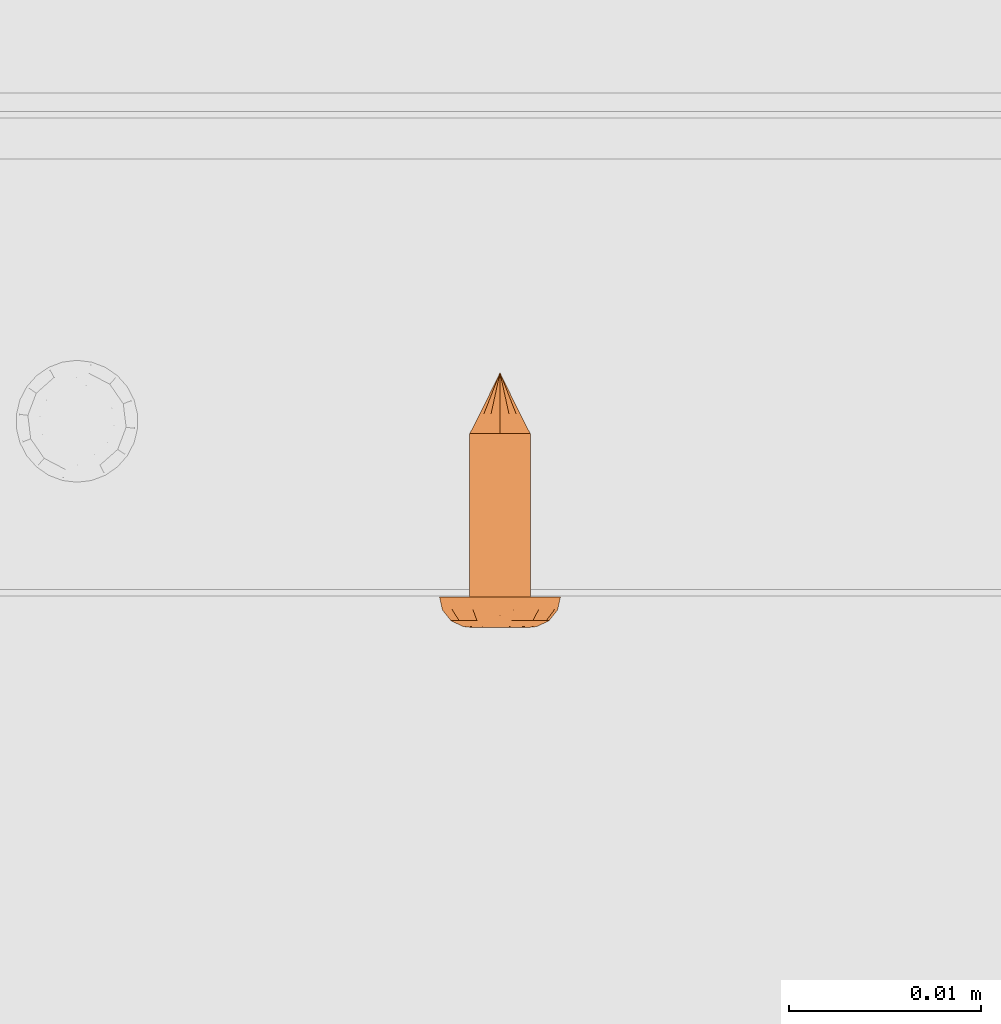
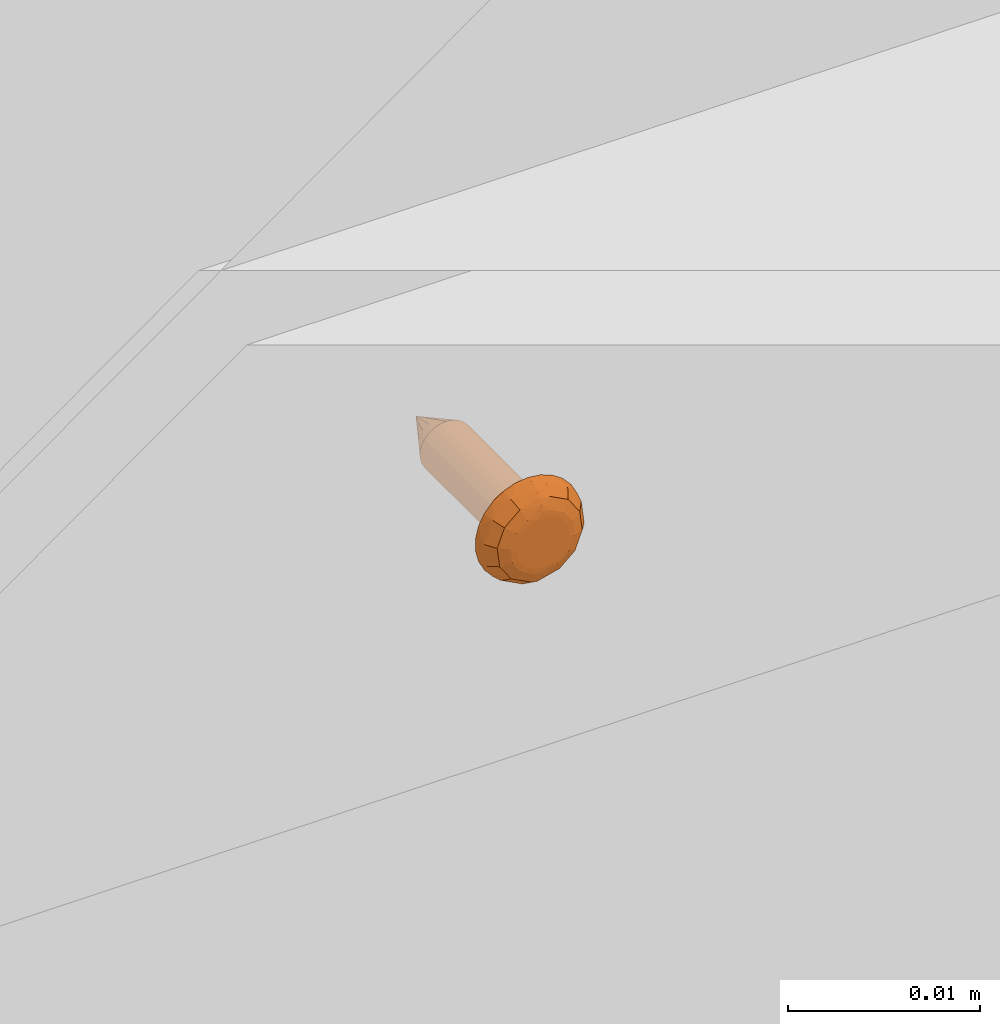
# One storey, part 44 of 44: 1 proxy.
"""IFC4 building model written with IfcOpenShell, lengths in feet."""

from ifc_helpers import new_model, entity, si_unit, converted_unit, derived_unit, direction, frame, origin, place, context, subcontext, project, spatial, source, transform, mapped, material, type_object, type_shapes, element, save


model = new_model("IFC4")

# Units and contexts
model_context = context("Model", 3, precision=0.0001, world=origin(), true_north=direction((6.12303176911189e-17, 1.0)))
body_context = subcontext(model_context, "Body", "Model", "MODEL_VIEW")
ifc_project = project(units=[converted_unit("LENGTHUNIT", "FOOT", entity("IfcRatioMeasure", 0.3048), si_unit("LENGTHUNIT", "METRE"), dimensions=[1, 0, 0, 0, 0, 0, 0]), converted_unit("AREAUNIT", "SQUARE FOOT", entity("IfcRatioMeasure", 0.09290304), si_unit("AREAUNIT", "SQUARE_METRE"), dimensions=[2, 0, 0, 0, 0, 0, 0]), converted_unit("VOLUMEUNIT", "CUBIC FOOT", entity("IfcRatioMeasure", 0.028316846592), si_unit("VOLUMEUNIT", "CUBIC_METRE"), dimensions=[3, 0, 0, 0, 0, 0, 0]), converted_unit("PLANEANGLEUNIT", "DEGREE", entity("IfcRatioMeasure", 0.0174532925199433), si_unit("PLANEANGLEUNIT", "RADIAN"), dimensions=[0, 0, 0, 0, 0, 0, 0]), si_unit("MASSUNIT", "GRAM", prefix="KILO"), derived_unit("MASSDENSITYUNIT", [(si_unit("MASSUNIT", "GRAM", prefix="KILO"), 1), (si_unit("LENGTHUNIT", "METRE"), -3)]), derived_unit("MOMENTOFINERTIAUNIT", [(si_unit("LENGTHUNIT", "METRE"), 4)]), si_unit("TIMEUNIT", "SECOND"), si_unit("FREQUENCYUNIT", "HERTZ"), si_unit("THERMODYNAMICTEMPERATUREUNIT", "DEGREE_CELSIUS"), derived_unit("THERMALTRANSMITTANCEUNIT", [(si_unit("MASSUNIT", "GRAM", prefix="KILO"), 1), (si_unit("THERMODYNAMICTEMPERATUREUNIT", "KELVIN"), -1), (si_unit("TIMEUNIT", "SECOND"), -3)]), derived_unit("VOLUMETRICFLOWRATEUNIT", [(si_unit("LENGTHUNIT", "METRE"), 3), (si_unit("TIMEUNIT", "SECOND"), -1)]), si_unit("ELECTRICCURRENTUNIT", "AMPERE"), si_unit("ELECTRICVOLTAGEUNIT", "VOLT"), si_unit("POWERUNIT", "WATT"), si_unit("FORCEUNIT", "NEWTON"), si_unit("ILLUMINANCEUNIT", "LUX"), si_unit("LUMINOUSFLUXUNIT", "LUMEN"), si_unit("LUMINOUSINTENSITYUNIT", "CANDELA"), derived_unit("USERDEFINED", [(si_unit("MASSUNIT", "GRAM", prefix="KILO"), -1), (si_unit("LENGTHUNIT", "METRE"), -2), (si_unit("TIMEUNIT", "SECOND"), 3), (si_unit("LUMINOUSFLUXUNIT", "LUMEN"), 1)]), derived_unit("LINEARVELOCITYUNIT", [(si_unit("LENGTHUNIT", "METRE"), 1), (si_unit("TIMEUNIT", "SECOND"), -1)]), si_unit("PRESSUREUNIT", "PASCAL"), derived_unit("USERDEFINED", [(si_unit("LENGTHUNIT", "METRE"), -2), (si_unit("MASSUNIT", "GRAM", prefix="KILO"), 1), (si_unit("TIMEUNIT", "SECOND"), -2)]), derived_unit("LINEARFORCEUNIT", [(si_unit("MASSUNIT", "GRAM", prefix="KILO"), 1), (si_unit("LENGTHUNIT", "METRE"), 1), (si_unit("TIMEUNIT", "SECOND"), -2), (si_unit("LENGTHUNIT", "METRE"), -1)]), derived_unit("PLANARFORCEUNIT", [(si_unit("MASSUNIT", "GRAM", prefix="KILO"), 1), (si_unit("LENGTHUNIT", "METRE"), 1), (si_unit("TIMEUNIT", "SECOND"), -2), (si_unit("LENGTHUNIT", "METRE"), -2)])], contexts=[model_context])

# Site, building, storey
site_placement = place(None, origin())
site = spatial("IfcSite", under=ifc_project, at=site_placement, CompositionType="ELEMENT")
building_placement = place(site_placement, origin())
building = spatial("IfcBuilding", under=site, at=building_placement, CompositionType="ELEMENT")
storey_placement = place(building_placement, origin())
storey = spatial("IfcBuildingStorey", under=building, at=storey_placement, CompositionType="ELEMENT", Elevation=0.0)

# Proxy
ifc_material = material(Category="Materials")
building_element_proxy_type = type_object("IfcBuildingElementProxyType", PredefinedType="NOTDEFINED", material=ifc_material)
cartesian_point_1 = entity("IfcCartesianPoint", [0.0, -0.00520833333344342, -0.0278812538651513])
vertex_point_1 = entity("IfcVertexPoint", cartesian_point_1)
cartesian_point_2 = entity("IfcCartesianPoint", [0.0, 0.00520833333334731, -0.0278812538651514])
vertex_point_2 = entity("IfcVertexPoint", cartesian_point_2)
cartesian_point_3 = entity("IfcCartesianPoint", [0.0, 0.0, -0.0278812538651514])
ifc_direction_1 = entity("IfcDirection", [0.0, 0.0, 1.0])
ifc_direction_2 = entity("IfcDirection", [0.0, 1.0, 0.0])
edge_curve_1 = entity("IfcEdgeCurve", vertex_point_1, vertex_point_2, entity("IfcTrimmedCurve", entity("IfcCircle", entity("IfcAxis2Placement3D", cartesian_point_3, ifc_direction_1, ifc_direction_2), 0.00520833333339537), [cartesian_point_1], [cartesian_point_2], True, "CARTESIAN"), True)
vertex_point_3 = entity("IfcVertexPoint", cartesian_point_3)
ifc_direction_3 = entity("IfcDirection", [0.0, -1.0, 0.0])
edge_curve_2 = entity("IfcEdgeCurve", vertex_point_2, vertex_point_3, entity("IfcTrimmedCurve", entity("IfcLine", cartesian_point_2, entity("IfcVector", ifc_direction_3, 1.0)), [cartesian_point_2], [cartesian_point_3], True, "CARTESIAN"), True)
edge_curve_3 = entity("IfcEdgeCurve", vertex_point_3, vertex_point_1, entity("IfcTrimmedCurve", entity("IfcLine", cartesian_point_3, entity("IfcVector", ifc_direction_3, 1.0)), [cartesian_point_3], [cartesian_point_1], True, "CARTESIAN"), True)
edge_curve_4 = entity("IfcEdgeCurve", vertex_point_2, vertex_point_1, entity("IfcTrimmedCurve", entity("IfcCircle", entity("IfcAxis2Placement3D", cartesian_point_3, ifc_direction_1, ifc_direction_2), 0.00520833333339537), [cartesian_point_2], [cartesian_point_1], True, "CARTESIAN"), True)
cartesian_point_4 = entity("IfcCartesianPoint", [0.0, 0.0, -0.0382979205315861])
vertex_point_4 = entity("IfcVertexPoint", cartesian_point_4)
edge_curve_5 = entity("IfcEdgeCurve", vertex_point_4, vertex_point_2, entity("IfcTrimmedCurve", entity("IfcLine", cartesian_point_4, entity("IfcVector", entity("IfcDirection", [0.0, 0.447213595512766, 0.894427190993512]), 1.0)), [cartesian_point_4], [cartesian_point_2], True, "CARTESIAN"), True)
edge_curve_6 = entity("IfcEdgeCurve", vertex_point_1, vertex_point_4, entity("IfcTrimmedCurve", entity("IfcLine", cartesian_point_1, entity("IfcVector", entity("IfcDirection", [0.0, 0.447213595512751, -0.894427190993519]), 1.0)), [cartesian_point_1], [cartesian_point_4], True, "CARTESIAN"), True)
cartesian_point_5 = entity("IfcCartesianPoint", [-0.0052083333333639, 0.0, -0.0278812538651513])
cartesian_point_6 = entity("IfcCartesianPoint", [0.0, 0.0, -0.0327501051227764])
ifc_direction_4 = entity("IfcDirection", [0.0, 0.0, -1.0])
cartesian_point_7 = entity("IfcCartesianPoint", [0.0, 0.0104166666665518, 0.0])
vertex_point_5 = entity("IfcVertexPoint", cartesian_point_7)
cartesian_point_8 = entity("IfcCartesianPoint", [0.0, -0.0104166666669052, 0.0])
vertex_point_6 = entity("IfcVertexPoint", cartesian_point_8)
cartesian_point_9 = entity("IfcCartesianPoint", [0.0, 0.0, 0.0])
ifc_direction_5 = entity("IfcDirection", [0.0, 0.0, -1.0])
ifc_direction_6 = entity("IfcDirection", [0.0, -1.0, 0.0])
edge_curve_7 = entity("IfcEdgeCurve", vertex_point_5, vertex_point_6, entity("IfcTrimmedCurve", entity("IfcCircle", entity("IfcAxis2Placement3D", cartesian_point_9, ifc_direction_5, ifc_direction_6), 0.0104166666667285), [cartesian_point_7], [cartesian_point_8], True, "CARTESIAN"), True)
vertex_point_7 = entity("IfcVertexPoint", cartesian_point_9)
ifc_direction_7 = entity("IfcDirection", [0.0, 1.0, 0.0])
edge_curve_8 = entity("IfcEdgeCurve", vertex_point_6, vertex_point_7, entity("IfcTrimmedCurve", entity("IfcLine", cartesian_point_8, entity("IfcVector", ifc_direction_7, 1.0)), [cartesian_point_8], [cartesian_point_9], True, "CARTESIAN"), True)
edge_curve_9 = entity("IfcEdgeCurve", vertex_point_7, vertex_point_5, entity("IfcTrimmedCurve", entity("IfcLine", cartesian_point_9, entity("IfcVector", ifc_direction_7, 1.0)), [cartesian_point_9], [cartesian_point_7], True, "CARTESIAN"), True)
edge_curve_10 = entity("IfcEdgeCurve", vertex_point_6, vertex_point_5, entity("IfcTrimmedCurve", entity("IfcCircle", entity("IfcAxis2Placement3D", cartesian_point_9, ifc_direction_5, ifc_direction_6), 0.0104166666667285), [cartesian_point_8], [cartesian_point_7], True, "CARTESIAN"), True)
cartesian_point_10 = entity("IfcCartesianPoint", [0.0, 0.0, 0.00520833333310164])
vertex_point_8 = entity("IfcVertexPoint", cartesian_point_10)
cartesian_point_11 = entity("IfcCartesianPoint", [0.0, -0.00520833333357187, 0.00520833333310168])
vertex_point_9 = entity("IfcVertexPoint", cartesian_point_11)
edge_curve_11 = entity("IfcEdgeCurve", vertex_point_8, vertex_point_9, entity("IfcTrimmedCurve", entity("IfcLine", cartesian_point_10, entity("IfcVector", ifc_direction_6, 1.0)), [cartesian_point_10], [cartesian_point_11], True, "CARTESIAN"), True)
cartesian_point_12 = entity("IfcCartesianPoint", [0.0, 0.00520833333321853, 0.00520833333310159])
vertex_point_10 = entity("IfcVertexPoint", cartesian_point_12)
ifc_direction_8 = entity("IfcDirection", [0.0, 0.0, 1.0])
edge_curve_12 = entity("IfcEdgeCurve", vertex_point_9, vertex_point_10, entity("IfcTrimmedCurve", entity("IfcCircle", entity("IfcAxis2Placement3D", cartesian_point_10, ifc_direction_8, ifc_direction_6), 0.00520833333339523), [cartesian_point_11], [cartesian_point_12], True, "CARTESIAN"), True)
edge_curve_13 = entity("IfcEdgeCurve", vertex_point_10, vertex_point_8, entity("IfcTrimmedCurve", entity("IfcLine", cartesian_point_12, entity("IfcVector", ifc_direction_6, 1.0)), [cartesian_point_12], [cartesian_point_10], True, "CARTESIAN"), True)
edge_curve_14 = entity("IfcEdgeCurve", vertex_point_10, vertex_point_9, entity("IfcTrimmedCurve", entity("IfcCircle", entity("IfcAxis2Placement3D", cartesian_point_10, ifc_direction_8, ifc_direction_6), 0.00520833333339523), [cartesian_point_12], [cartesian_point_11], True, "CARTESIAN"), True)
ifc_direction_9 = entity("IfcDirection", [1.0, 0.0, 0.0])
edge_curve_15 = entity("IfcEdgeCurve", vertex_point_9, vertex_point_6, entity("IfcTrimmedCurve", entity("IfcCircle", entity("IfcAxis2Placement3D", entity("IfcCartesianPoint", [0.0, -0.00520833333357193, 0.0]), ifc_direction_9, ifc_direction_6), 0.00520833333333331), [cartesian_point_11], [cartesian_point_8], True, "CARTESIAN"), True)
edge_curve_16 = entity("IfcEdgeCurve", vertex_point_5, vertex_point_10, entity("IfcTrimmedCurve", entity("IfcCircle", entity("IfcAxis2Placement3D", entity("IfcCartesianPoint", [0.0, 0.0052083333332185, 0.0]), ifc_direction_9, ifc_direction_7), 0.00520833333333331), [cartesian_point_7], [cartesian_point_12], True, "CARTESIAN"), True)
cartesian_point_13 = entity("IfcCartesianPoint", [0.00520833333332085, 0.0, 0.0])
cartesian_point_14 = entity("IfcCartesianPoint", [0.0104166666666542, 0.0, 0.0])
cartesian_point_15 = entity("IfcCartesianPoint", [0.0052083333333208, 0.0, 0.00520833333310163])
cartesian_point_16 = entity("IfcCartesianPoint", [0.0, -0.00520833333348769, 0.0])
vertex_point_11 = entity("IfcVertexPoint", cartesian_point_16)
cartesian_point_17 = entity("IfcCartesianPoint", [0.0, 0.00520833333317898, 0.0])
vertex_point_12 = entity("IfcVertexPoint", cartesian_point_17)
cartesian_point_18 = entity("IfcCartesianPoint", [0.0, 0.0, 0.0])
ifc_direction_10 = entity("IfcDirection", [0.0, 0.0, 1.0])
ifc_direction_11 = entity("IfcDirection", [0.0, 1.0, 0.0])
edge_curve_17 = entity("IfcEdgeCurve", vertex_point_11, vertex_point_12, entity("IfcTrimmedCurve", entity("IfcCircle", entity("IfcAxis2Placement3D", cartesian_point_18, ifc_direction_10, ifc_direction_11), 0.00520833333333333), [cartesian_point_16], [cartesian_point_17], True, "CARTESIAN"), True)
edge_curve_18 = entity("IfcEdgeCurve", vertex_point_12, vertex_point_11, entity("IfcTrimmedCurve", entity("IfcCircle", entity("IfcAxis2Placement3D", cartesian_point_18, ifc_direction_10, ifc_direction_11), 0.00520833333333333), [cartesian_point_17], [cartesian_point_16], True, "CARTESIAN"), True)
cartesian_point_19 = entity("IfcCartesianPoint", [0.0, -0.00520833333348793, -0.0278812538652589])
vertex_point_13 = entity("IfcVertexPoint", cartesian_point_19)
cartesian_point_20 = entity("IfcCartesianPoint", [0.0, 0.00520833333317874, -0.027881253865259])
vertex_point_14 = entity("IfcVertexPoint", cartesian_point_20)
cartesian_point_21 = entity("IfcCartesianPoint", [0.0, 0.0, -0.027881253865259])
ifc_direction_12 = entity("IfcDirection", [0.0, 0.0, -1.0])
edge_curve_19 = entity("IfcEdgeCurve", vertex_point_13, vertex_point_14, entity("IfcTrimmedCurve", entity("IfcCircle", entity("IfcAxis2Placement3D", cartesian_point_21, ifc_direction_12, ifc_direction_11), 0.00520833333333333), [cartesian_point_19], [cartesian_point_20], True, "CARTESIAN"), True)
edge_curve_20 = entity("IfcEdgeCurve", vertex_point_14, vertex_point_13, entity("IfcTrimmedCurve", entity("IfcCircle", entity("IfcAxis2Placement3D", cartesian_point_21, ifc_direction_12, ifc_direction_11), 0.00520833333333333), [cartesian_point_20], [cartesian_point_19], True, "CARTESIAN"), True)
edge_curve_21 = entity("IfcEdgeCurve", vertex_point_11, vertex_point_13, entity("IfcTrimmedCurve", entity("IfcLine", cartesian_point_16, entity("IfcVector", ifc_direction_12, 1.0)), [cartesian_point_16], [cartesian_point_19], True, "CARTESIAN"), True)
edge_curve_22 = entity("IfcEdgeCurve", vertex_point_14, vertex_point_12, entity("IfcTrimmedCurve", entity("IfcLine", cartesian_point_17, entity("IfcVector", ifc_direction_10, 1.0)), [cartesian_point_20], [cartesian_point_17], True, "CARTESIAN"), True)
shared_shape = source(origin(), body_context, "Body", "AdvancedBrep", [
    entity("IfcAdvancedBrep", entity("IfcClosedShell", [entity("IfcAdvancedFace", [entity("IfcFaceOuterBound", entity("IfcEdgeLoop", [entity("IfcOrientedEdge", None, None, edge_curve_1, True), entity("IfcOrientedEdge", None, None, edge_curve_2, True), entity("IfcOrientedEdge", None, None, edge_curve_3, True)]), True)], entity("IfcPlane", entity("IfcAxis2Placement3D", cartesian_point_3, ifc_direction_1, ifc_direction_2)), True), entity("IfcAdvancedFace", [entity("IfcFaceOuterBound", entity("IfcEdgeLoop", [entity("IfcOrientedEdge", None, None, edge_curve_4, True), entity("IfcOrientedEdge", None, None, edge_curve_3, False), entity("IfcOrientedEdge", None, None, edge_curve_2, False)]), True)], entity("IfcPlane", entity("IfcAxis2Placement3D", cartesian_point_3, ifc_direction_1, ifc_direction_2)), True), entity("IfcAdvancedFace", [entity("IfcFaceOuterBound", entity("IfcEdgeLoop", [entity("IfcOrientedEdge", None, None, edge_curve_5, True), entity("IfcOrientedEdge", None, None, edge_curve_1, False), entity("IfcOrientedEdge", None, None, edge_curve_6, True)]), True)], entity("IfcSurfaceOfRevolution", entity("IfcArbitraryOpenProfileDef", "CURVE", None, entity("IfcTrimmedCurve", entity("IfcLine", cartesian_point_4, entity("IfcVector", entity("IfcDirection", [0.447213595512749, 0.0, -0.894427190993521]), 1.0)), [cartesian_point_5], [cartesian_point_4], True, "CARTESIAN")), None, entity("IfcAxis1Placement", cartesian_point_6, ifc_direction_4)), True), entity("IfcAdvancedFace", [entity("IfcFaceOuterBound", entity("IfcEdgeLoop", [entity("IfcOrientedEdge", None, None, edge_curve_6, False), entity("IfcOrientedEdge", None, None, edge_curve_4, False), entity("IfcOrientedEdge", None, None, edge_curve_5, False)]), True)], entity("IfcSurfaceOfRevolution", entity("IfcArbitraryOpenProfileDef", "CURVE", None, entity("IfcTrimmedCurve", entity("IfcLine", cartesian_point_4, entity("IfcVector", entity("IfcDirection", [0.447213595512749, 0.0, -0.894427190993521]), 1.0)), [cartesian_point_5], [cartesian_point_4], True, "CARTESIAN")), None, entity("IfcAxis1Placement", cartesian_point_6, ifc_direction_4)), True)])),
    entity("IfcAdvancedBrep", entity("IfcClosedShell", [entity("IfcAdvancedFace", [entity("IfcFaceOuterBound", entity("IfcEdgeLoop", [entity("IfcOrientedEdge", None, None, edge_curve_7, True), entity("IfcOrientedEdge", None, None, edge_curve_8, True), entity("IfcOrientedEdge", None, None, edge_curve_9, True)]), True)], entity("IfcPlane", entity("IfcAxis2Placement3D", cartesian_point_9, ifc_direction_5, ifc_direction_6)), True), entity("IfcAdvancedFace", [entity("IfcFaceOuterBound", entity("IfcEdgeLoop", [entity("IfcOrientedEdge", None, None, edge_curve_10, True), entity("IfcOrientedEdge", None, None, edge_curve_9, False), entity("IfcOrientedEdge", None, None, edge_curve_8, False)]), True)], entity("IfcPlane", entity("IfcAxis2Placement3D", cartesian_point_9, ifc_direction_5, ifc_direction_6)), True), entity("IfcAdvancedFace", [entity("IfcFaceOuterBound", entity("IfcEdgeLoop", [entity("IfcOrientedEdge", None, None, edge_curve_11, True), entity("IfcOrientedEdge", None, None, edge_curve_12, True), entity("IfcOrientedEdge", None, None, edge_curve_13, True)]), True)], entity("IfcPlane", entity("IfcAxis2Placement3D", cartesian_point_10, ifc_direction_8, ifc_direction_6)), True), entity("IfcAdvancedFace", [entity("IfcFaceOuterBound", entity("IfcEdgeLoop", [entity("IfcOrientedEdge", None, None, edge_curve_13, False), entity("IfcOrientedEdge", None, None, edge_curve_14, True), entity("IfcOrientedEdge", None, None, edge_curve_11, False)]), True)], entity("IfcPlane", entity("IfcAxis2Placement3D", cartesian_point_10, ifc_direction_8, ifc_direction_6)), True), entity("IfcAdvancedFace", [entity("IfcFaceOuterBound", entity("IfcEdgeLoop", [entity("IfcOrientedEdge", None, None, edge_curve_12, False), entity("IfcOrientedEdge", None, None, edge_curve_15, True), entity("IfcOrientedEdge", None, None, edge_curve_7, False), entity("IfcOrientedEdge", None, None, edge_curve_16, True)]), True)], entity("IfcSurfaceOfRevolution", entity("IfcArbitraryOpenProfileDef", "CURVE", None, entity("IfcTrimmedCurve", entity("IfcCircle", entity("IfcAxis2Placement3D", cartesian_point_13, ifc_direction_6, ifc_direction_9), 0.00520833333333331), [cartesian_point_14], [cartesian_point_15], True, "CARTESIAN")), None, entity("IfcAxis1Placement", cartesian_point_10, ifc_direction_8)), True), entity("IfcAdvancedFace", [entity("IfcFaceOuterBound", entity("IfcEdgeLoop", [entity("IfcOrientedEdge", None, None, edge_curve_14, False), entity("IfcOrientedEdge", None, None, edge_curve_16, False), entity("IfcOrientedEdge", None, None, edge_curve_10, False), entity("IfcOrientedEdge", None, None, edge_curve_15, False)]), True)], entity("IfcSurfaceOfRevolution", entity("IfcArbitraryOpenProfileDef", "CURVE", None, entity("IfcTrimmedCurve", entity("IfcCircle", entity("IfcAxis2Placement3D", cartesian_point_13, ifc_direction_6, ifc_direction_9), 0.00520833333333331), [cartesian_point_14], [cartesian_point_15], True, "CARTESIAN")), None, entity("IfcAxis1Placement", cartesian_point_10, ifc_direction_8)), True)])),
    entity("IfcAdvancedBrep", entity("IfcClosedShell", [entity("IfcAdvancedFace", [entity("IfcFaceOuterBound", entity("IfcEdgeLoop", [entity("IfcOrientedEdge", None, None, edge_curve_17, True), entity("IfcOrientedEdge", None, None, edge_curve_18, True)]), True)], entity("IfcPlane", entity("IfcAxis2Placement3D", cartesian_point_17, ifc_direction_10, entity("IfcDirection", [-1.0, 0.0, 0.0]))), True), entity("IfcAdvancedFace", [entity("IfcFaceOuterBound", entity("IfcEdgeLoop", [entity("IfcOrientedEdge", None, None, edge_curve_19, True), entity("IfcOrientedEdge", None, None, edge_curve_20, True)]), True)], entity("IfcPlane", entity("IfcAxis2Placement3D", cartesian_point_20, ifc_direction_12, entity("IfcDirection", [1.0, 0.0, 0.0]))), True), entity("IfcAdvancedFace", [entity("IfcFaceOuterBound", entity("IfcEdgeLoop", [entity("IfcOrientedEdge", None, None, edge_curve_17, False), entity("IfcOrientedEdge", None, None, edge_curve_21, True), entity("IfcOrientedEdge", None, None, edge_curve_20, False), entity("IfcOrientedEdge", None, None, edge_curve_22, True)]), True)], entity("IfcCylindricalSurface", entity("IfcAxis2Placement3D", cartesian_point_21, ifc_direction_10, ifc_direction_11), 0.00520833333333333), True), entity("IfcAdvancedFace", [entity("IfcFaceOuterBound", entity("IfcEdgeLoop", [entity("IfcOrientedEdge", None, None, edge_curve_18, False), entity("IfcOrientedEdge", None, None, edge_curve_22, False), entity("IfcOrientedEdge", None, None, edge_curve_19, False), entity("IfcOrientedEdge", None, None, edge_curve_21, False)]), True)], entity("IfcCylindricalSurface", entity("IfcAxis2Placement3D", cartesian_point_21, ifc_direction_10, ifc_direction_11), 0.00520833333333333), True)])),
])
type_shapes(building_element_proxy_type, [shared_shape])
proxy_placement = place(storey_placement, frame((1491.12242509946, 4.66460279604269, 7.94054131618747), z_axis=(0.0, -1.0, 0.0), x_axis=(1.0, 0.0, 0.0)))
element("IfcBuildingElementProxy", 1, at=proxy_placement, inside=storey, type_object=building_element_proxy_type, material=ifc_material, PredefinedType="NOTDEFINED", context=body_context, shape_type="MappedRepresentation", body=[
    mapped(shared_shape, transform((0.0, 0.0, 0.0), scale=1.0)),
])

save(model, "model.ifc")
